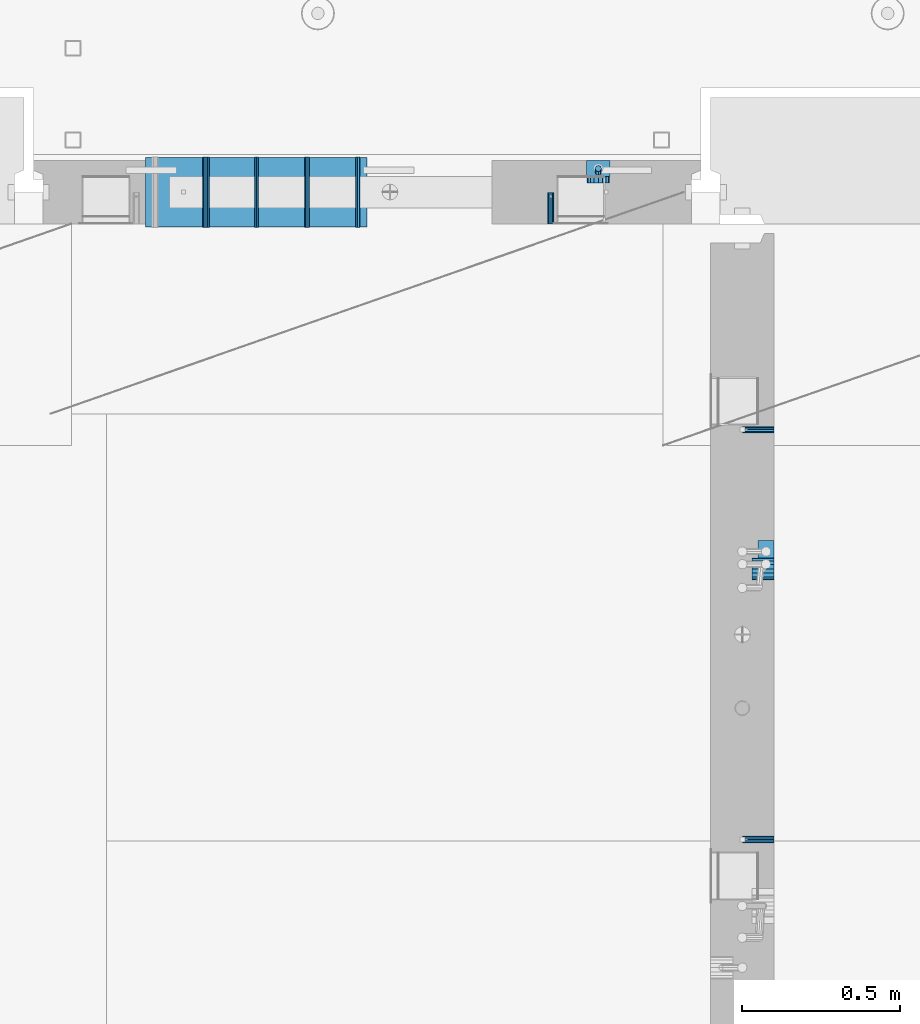
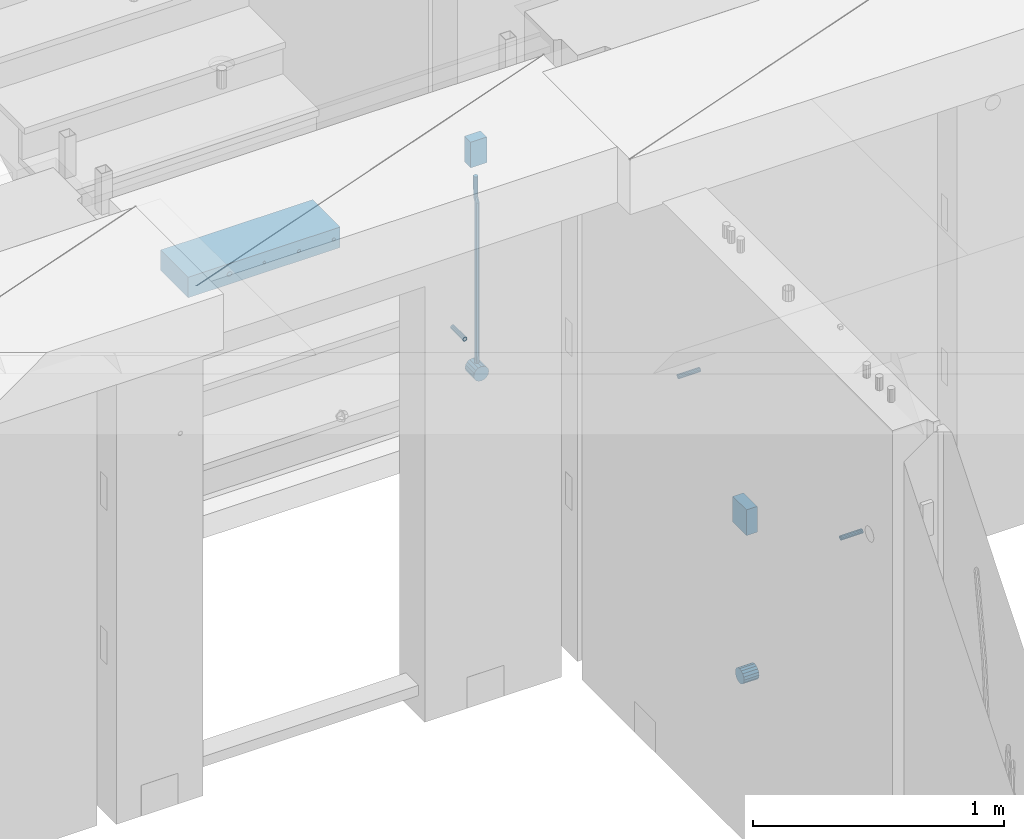
# One storey, part 149 of 349: 13 beams, 5 elements without a shape of their own.
"""IFC2X3 building model written with IfcOpenShell, lengths in millimetres."""

from ifc_helpers import new_model, si_unit, frame, origin_with_axes, place, context, subcontext, project, spatial, faceted_brep, material, type_object, element, aggregate, save


model = new_model("IFC2X3")

# Units and contexts
model_context = context("Model", 3, precision=1e-05, world=origin_with_axes())
body_context = subcontext(model_context, "Body", "Model", "MODEL_VIEW")
ifc_project = project(units=[si_unit("LENGTHUNIT", "METRE", prefix="MILLI"), si_unit("AREAUNIT", "SQUARE_METRE"), si_unit("VOLUMEUNIT", "CUBIC_METRE"), si_unit("MASSUNIT", "GRAM", prefix="KILO"), si_unit("TIMEUNIT", "SECOND"), si_unit("PLANEANGLEUNIT", "RADIAN"), si_unit("SOLIDANGLEUNIT", "STERADIAN"), si_unit("THERMODYNAMICTEMPERATUREUNIT", "DEGREE_CELSIUS"), si_unit("LUMINOUSINTENSITYUNIT", "LUMEN")], contexts=[model_context])

# Site, building, storey
site_placement = place(None, origin_with_axes())
site = spatial("IfcSite", under=ifc_project, at=site_placement, CompositionType="ELEMENT")
building_placement = place(site_placement, origin_with_axes())
building = spatial("IfcBuilding", under=site, at=building_placement, CompositionType="ELEMENT")
storey_placement = place(building_placement, origin_with_axes())
storey = spatial("IfcBuildingStorey", under=building, at=storey_placement, Name="4", CompositionType="ELEMENT", Elevation=0.0)

# Assemblies, beams
assembly_1_placement = place(storey_placement, origin_with_axes())
assembly_1 = element("IfcElementAssembly", 1, at=assembly_1_placement, inside=storey, AssemblyPlace="NOTDEFINED", PredefinedType="REINFORCEMENT_UNIT")
assembly_2_placement = place(assembly_1_placement, origin_with_axes())
assembly_2 = element("IfcElementAssembly", 2, at=assembly_2_placement, Name="Steel Assembly", AssemblyPlace="NOTDEFINED", PredefinedType="RIGID_FRAME")
ifc_material_1 = material(Name="STEEL/Steel_Undefined")
beam_type_1 = type_object("IfcBeamType", PredefinedType="NOTDEFINED")
beam_1_placement = place(assembly_2_placement, frame((21910.0, 13134.9999119588, 92555.0), z_axis=(0.0, -1.0, 0.0), x_axis=(-1.0, 3.00000001838171e-08, 0.0)))
beam_1 = element("IfcBeam", 3, at=beam_1_placement, type_object=beam_type_1, material=ifc_material_1, Name="M16", context=body_context, shape_type="Brep", body=[
    faceted_brep([(0.0, -8.49999999999272, -1.45519152283669e-11), (0.0, -7.36121593215648, 4.24999999998545), (100.000000000262, -7.36121593215648, 4.24999999998545), (100.000000000262, -8.49999999999272, -1.45519152283669e-11), (0.0, -4.24999999998545, 7.36121593216376), (100.000000000262, -4.24999999998545, 7.36121593216376), (0.0, 1.45519152283669e-11, 8.49999999998545), (100.000000000262, 1.45519152283669e-11, 8.49999999998545), (0.0, 4.25000000001455, 7.36121593216376), (100.000000000262, 4.25000000001455, 7.36121593216376), (0.0, 7.36121593217104, 4.24999999998545), (100.000000000262, 7.36121593217104, 4.24999999998545), (0.0, 8.50000000000728, 0.0), (100.000000000262, 8.50000000000728, 0.0), (0.0, 7.36121593217104, -4.25000000001455), (100.000000000262, 7.36121593217104, -4.25000000001455), (0.0, 4.25000000000728, -7.36121593219286), (100.000000000262, 4.25000000000728, -7.36121593219286), (0.0, 7.27595761418343e-12, -8.5), (100.000000000262, 7.27595761418343e-12, -8.5), (0.0, -4.24999999999272, -7.36121593217831), (100.000000000262, -4.24999999999272, -7.36121593217831), (0.0, -7.36121593215648, -4.25), (100.000000000262, -7.36121593215648, -4.25), (0.0, -10.4999999999927, -1.45519152283669e-11), (0.0, -9.09326673972828, -5.25000000001455), (100.000000000262, -9.09326673972828, -5.25000000001455), (100.000000000262, -10.4999999999927, -1.45519152283669e-11), (0.0, -5.24999999998545, -9.09326673974283), (100.000000000262, -5.24999999998545, -9.09326673974283), (0.0, 7.27595761418343e-12, -10.5), (100.000000000262, 7.27595761418343e-12, -10.5), (0.0, 5.25000000001455, -9.09326673975738), (100.000000000262, 5.25000000001455, -9.09326673975738), (0.0, 9.09326673975011, -5.25000000001455), (100.000000000262, 9.09326673975011, -5.25000000001455), (0.0, 10.5000000000073, -1.45519152283669e-11), (100.000000000262, 10.5000000000073, -1.45519152283669e-11), (0.0, 9.09326673975011, 5.25), (100.000000000262, 9.09326673975011, 5.25), (0.0, 5.25000000000728, 9.09326673972828), (100.000000000262, 5.25000000000728, 9.09326673972828), (0.0, 1.45519152283669e-11, 10.4999999999854), (100.000000000262, 1.45519152283669e-11, 10.4999999999854), (0.0, -5.24999999999272, 9.09326673972828), (100.000000000262, -5.24999999999272, 9.09326673972828), (0.0, -9.09326673972828, 5.24999999998545), (100.000000000262, -9.09326673972828, 5.24999999998545)], [[[0, 1, 2, 3]], [[1, 4, 5, 2]], [[4, 6, 7, 5]], [[6, 8, 9, 7]], [[8, 10, 11, 9]], [[10, 12, 13, 11]], [[12, 14, 15, 13]], [[14, 16, 17, 15]], [[16, 18, 19, 17]], [[18, 20, 21, 19]], [[20, 22, 23, 21]], [[22, 0, 3, 23]], [[24, 25, 26, 27]], [[25, 28, 29, 26]], [[28, 30, 31, 29]], [[30, 32, 33, 31]], [[32, 34, 35, 33]], [[34, 36, 37, 35]], [[36, 38, 39, 37]], [[38, 40, 41, 39]], [[40, 42, 43, 41]], [[42, 44, 45, 43]], [[44, 46, 47, 45]], [[46, 24, 27, 47]], [[29, 31, 33, 35, 37, 39, 41, 43, 45, 47, 27, 26], [5, 7, 9, 11, 13, 15, 17, 19, 21, 23, 3, 2]], [[46, 44, 42, 40, 38, 36, 34, 32, 30, 28, 25, 24], [22, 20, 18, 16, 14, 12, 10, 8, 6, 4, 1, 0]]]),
])
aggregate(assembly_2, [beam_1])
assembly_3_placement = place(assembly_1_placement, origin_with_axes())
assembly_3 = element("IfcElementAssembly", 4, at=assembly_3_placement, Name="Steel Assembly", AssemblyPlace="NOTDEFINED", PredefinedType="RIGID_FRAME")
beam_2_placement = place(assembly_3_placement, frame((21910.0, 14429.9999119589, 92555.0), z_axis=(0.0, 1.0, 0.0), x_axis=(-1.0, 3.00000001838171e-08, 0.0)))
beam_2 = element("IfcBeam", 5, at=beam_2_placement, type_object=beam_type_1, material=ifc_material_1, Name="M16", context=body_context, shape_type="Brep", body=[
    faceted_brep([(0.0, -8.49999999999272, -1.45519152283669e-11), (0.0, -7.36121593215648, 4.24999999998545), (100.000000000262, -7.36121593215648, 4.24999999998545), (100.000000000262, -8.49999999999272, -1.45519152283669e-11), (0.0, -4.24999999998545, 7.36121593216376), (100.000000000262, -4.24999999998545, 7.36121593216376), (0.0, 1.45519152283669e-11, 8.49999999998545), (100.000000000262, 1.45519152283669e-11, 8.49999999998545), (0.0, 4.25000000001455, 7.36121593216376), (100.000000000262, 4.25000000001455, 7.36121593216376), (0.0, 7.36121593217104, 4.24999999998545), (100.000000000262, 7.36121593217104, 4.24999999998545), (0.0, 8.50000000000728, 0.0), (100.000000000262, 8.50000000000728, 0.0), (0.0, 7.36121593217104, -4.25000000001455), (100.000000000262, 7.36121593217104, -4.25000000001455), (0.0, 4.25000000000728, -7.36121593219286), (100.000000000262, 4.25000000000728, -7.36121593219286), (0.0, 7.27595761418343e-12, -8.5), (100.000000000262, 7.27595761418343e-12, -8.5), (0.0, -4.24999999999272, -7.36121593217831), (100.000000000262, -4.24999999999272, -7.36121593217831), (0.0, -7.36121593215648, -4.25), (100.000000000262, -7.36121593215648, -4.25), (0.0, -10.4999999999927, -1.45519152283669e-11), (0.0, -9.09326673972828, -5.25000000001455), (100.000000000262, -9.09326673972828, -5.25000000001455), (100.000000000262, -10.4999999999927, -1.45519152283669e-11), (0.0, -5.24999999998545, -9.09326673974283), (100.000000000262, -5.24999999998545, -9.09326673974283), (0.0, 7.27595761418343e-12, -10.5), (100.000000000262, 7.27595761418343e-12, -10.5), (0.0, 5.25000000001455, -9.09326673975738), (100.000000000262, 5.25000000001455, -9.09326673975738), (0.0, 9.09326673975011, -5.25000000001455), (100.000000000262, 9.09326673975011, -5.25000000001455), (0.0, 10.5000000000073, -1.45519152283669e-11), (100.000000000262, 10.5000000000073, -1.45519152283669e-11), (0.0, 9.09326673975011, 5.25), (100.000000000262, 9.09326673975011, 5.25), (0.0, 5.25000000000728, 9.09326673972828), (100.000000000262, 5.25000000000728, 9.09326673972828), (0.0, 1.45519152283669e-11, 10.4999999999854), (100.000000000262, 1.45519152283669e-11, 10.4999999999854), (0.0, -5.24999999999272, 9.09326673972828), (100.000000000262, -5.24999999999272, 9.09326673972828), (0.0, -9.09326673972828, 5.24999999998545), (100.000000000262, -9.09326673972828, 5.24999999998545)], [[[0, 1, 2, 3]], [[1, 4, 5, 2]], [[4, 6, 7, 5]], [[6, 8, 9, 7]], [[8, 10, 11, 9]], [[10, 12, 13, 11]], [[12, 14, 15, 13]], [[14, 16, 17, 15]], [[16, 18, 19, 17]], [[18, 20, 21, 19]], [[20, 22, 23, 21]], [[22, 0, 3, 23]], [[24, 25, 26, 27]], [[25, 28, 29, 26]], [[28, 30, 31, 29]], [[30, 32, 33, 31]], [[32, 34, 35, 33]], [[34, 36, 37, 35]], [[36, 38, 39, 37]], [[38, 40, 41, 39]], [[40, 42, 43, 41]], [[42, 44, 45, 43]], [[44, 46, 47, 45]], [[46, 24, 27, 47]], [[29, 31, 33, 35, 37, 39, 41, 43, 45, 47, 27, 26], [5, 7, 9, 11, 13, 15, 17, 19, 21, 23, 3, 2]], [[46, 44, 42, 40, 38, 36, 34, 32, 30, 28, 25, 24], [22, 20, 18, 16, 14, 12, 10, 8, 6, 4, 1, 0]]]),
])
aggregate(assembly_3, [beam_2])

assembly_4_placement = place(storey_placement, origin_with_axes())
assembly_4 = element("IfcElementAssembly", 6, at=assembly_4_placement, inside=storey, AssemblyPlace="NOTDEFINED", PredefinedType="REINFORCEMENT_UNIT")
assembly_5_placement = place(assembly_4_placement, origin_with_axes())
assembly_5 = element("IfcElementAssembly", 7, at=assembly_5_placement, Name="Steel Assembly", AssemblyPlace="NOTDEFINED", PredefinedType="RIGID_FRAME")
beam_3_placement = place(assembly_5_placement, frame((21205.004085231, 15080.0, 92555.0), z_axis=(1.0, 0.0, 0.0), x_axis=(0.0, 1.0, 0.0)))
beam_3 = element("IfcBeam", 8, at=beam_3_placement, type_object=beam_type_1, material=ifc_material_1, Name="M16", context=body_context, shape_type="Brep", body=[
    faceted_brep([(0.0, -8.49999999999272, -1.45519152283669e-11), (0.0, -7.36121593215648, 4.24999999998545), (100.000000000262, -7.36121593215648, 4.24999999998545), (100.000000000262, -8.49999999999272, -1.45519152283669e-11), (0.0, -4.24999999998545, 7.36121593216376), (100.000000000262, -4.24999999998545, 7.36121593216376), (0.0, 1.45519152283669e-11, 8.49999999998545), (100.000000000262, 1.45519152283669e-11, 8.49999999998545), (0.0, 4.25000000001455, 7.36121593216376), (100.000000000262, 4.25000000001455, 7.36121593216376), (0.0, 7.36121593217104, 4.24999999998545), (100.000000000262, 7.36121593217104, 4.24999999998545), (0.0, 8.50000000000728, 0.0), (100.000000000262, 8.50000000000728, 0.0), (0.0, 7.36121593217104, -4.25000000001455), (100.000000000262, 7.36121593217104, -4.25000000001455), (0.0, 4.25000000000728, -7.36121593219286), (100.000000000262, 4.25000000000728, -7.36121593219286), (0.0, 7.27595761418343e-12, -8.5), (100.000000000262, 7.27595761418343e-12, -8.5), (0.0, -4.24999999999272, -7.36121593217831), (100.000000000262, -4.24999999999272, -7.36121593217831), (0.0, -7.36121593215648, -4.25), (100.000000000262, -7.36121593215648, -4.25), (0.0, -10.4999999999927, -1.45519152283669e-11), (0.0, -9.09326673972828, -5.25000000001455), (100.000000000262, -9.09326673972828, -5.25000000001455), (100.000000000262, -10.4999999999927, -1.45519152283669e-11), (0.0, -5.24999999998545, -9.09326673974283), (100.000000000262, -5.24999999998545, -9.09326673974283), (0.0, 7.27595761418343e-12, -10.5), (100.000000000262, 7.27595761418343e-12, -10.5), (0.0, 5.25000000001455, -9.09326673975738), (100.000000000262, 5.25000000001455, -9.09326673975738), (0.0, 9.09326673975011, -5.25000000001455), (100.000000000262, 9.09326673975011, -5.25000000001455), (0.0, 10.5000000000073, -1.45519152283669e-11), (100.000000000262, 10.5000000000073, -1.45519152283669e-11), (0.0, 9.09326673975011, 5.25), (100.000000000262, 9.09326673975011, 5.25), (0.0, 5.25000000000728, 9.09326673972828), (100.000000000262, 5.25000000000728, 9.09326673972828), (0.0, 1.45519152283669e-11, 10.4999999999854), (100.000000000262, 1.45519152283669e-11, 10.4999999999854), (0.0, -5.24999999999272, 9.09326673972828), (100.000000000262, -5.24999999999272, 9.09326673972828), (0.0, -9.09326673972828, 5.24999999998545), (100.000000000262, -9.09326673972828, 5.24999999998545)], [[[0, 1, 2, 3]], [[1, 4, 5, 2]], [[4, 6, 7, 5]], [[6, 8, 9, 7]], [[8, 10, 11, 9]], [[10, 12, 13, 11]], [[12, 14, 15, 13]], [[14, 16, 17, 15]], [[16, 18, 19, 17]], [[18, 20, 21, 19]], [[20, 22, 23, 21]], [[22, 0, 3, 23]], [[24, 25, 26, 27]], [[25, 28, 29, 26]], [[28, 30, 31, 29]], [[30, 32, 33, 31]], [[32, 34, 35, 33]], [[34, 36, 37, 35]], [[36, 38, 39, 37]], [[38, 40, 41, 39]], [[40, 42, 43, 41]], [[42, 44, 45, 43]], [[44, 46, 47, 45]], [[46, 24, 27, 47]], [[29, 31, 33, 35, 37, 39, 41, 43, 45, 47, 27, 26], [5, 7, 9, 11, 13, 15, 17, 19, 21, 23, 3, 2]], [[46, 44, 42, 40, 38, 36, 34, 32, 30, 28, 25, 24], [22, 20, 18, 16, 14, 12, 10, 8, 6, 4, 1, 0]]]),
])
aggregate(assembly_5, [beam_3])
ifc_material_2 = material()
beam_type_2 = type_object("IfcBeamType", Name="D20", PredefinedType="NOTDEFINED")
beam_4_placement = place(assembly_4_placement, frame((21354.9999999958, 15245.0000022759, 92290.0), z_axis=(0.00020576299992186, -0.999642804629538, -0.0267249099901004), x_axis=(-4.30000201928125e-08, -0.0267249099948059, 0.999642825806181)))
beam_4 = element("IfcBeam", 9, at=beam_4_placement, type_object=beam_type_2, material=ifc_material_2, Name="JM20", ObjectType="D20", context=body_context, shape_type="Brep", body=[
    faceted_brep([(0.0, -10.0, 0.0), (-4.19531716033816e-08, -7.07106781186667, -7.07106781187031), (60.3581158964225, -7.07106779467358, -7.07106780560207), (60.3581159005553, -9.99999998281055, 6.26459950581193e-09), (0.0, 0.0, -10.0), (60.3581158930319, 1.71930878423154e-08, -9.9999999937354), (4.196772351861e-08, 7.07106781186303, -7.07106781186667), (60.3581158923917, 7.07106782905612, -7.07106780560207), (0.0, 10.0, 0.0), (60.3581158948509, 10.0000000171895, 6.26459950581193e-09), (4.196772351861e-08, 7.07106781185939, 7.07106781185939), (60.3581158989837, 7.07106782905612, 7.07106781813127), (0.0, 0.0, 10.0), (60.3581159023597, 1.71930878423154e-08, 10.0000000062646), (-4.19531716033816e-08, -7.07106781187031, 7.07106781185939), (60.358115903, -7.07106779467722, 7.07106781813127), (60.8972477222414, -7.07106779452079, -7.07106780554386), (60.991799419251, -9.99999998403655, 6.21366780251265e-09), (60.8581158930319, 1.7334969015792e-08, -9.99999999368447), (60.8972861483926, 7.07106782920528, -7.07106780554386), (60.9917724058905, 10.0000000159635, 6.21366780251265e-09), (61.0863241029147, 7.07106782926348, 7.07106781820403), (61.1254559321096, 1.7415004549548e-08, 10.0000000063446), (61.086285676749, -7.07106779446985, 7.07106781820403), (61.4361869218264, -7.07107072394501, -7.08547838249069), (61.6251751877571, -10.0000034255863, -0.0169367769813107), (61.35793724822, -2.69946758635342e-06, -10.0133646071736), (61.4362637644808, 7.07106489957732, -7.08547940969947), (61.6252838596702, 9.99999657411536, -0.0169382296771801), (61.8142721256008, 7.07106387247404, 7.0516033758322), (61.8925217992073, -4.15200702263974e-06, 9.97948960051872), (61.814195282961, -7.07107175104829, 7.05160440304098), (775.690073058257, -7.07495307777208, -26.1837562433175), (775.879061324187, -10.0038857794134, -19.1152146378081), (775.611823384636, -0.00388505329101463, -29.1116424680004), (775.690149900896, 7.06718254575026, -26.1837572705263), (775.8791699961, 9.99611422029193, -19.1152160905003), (776.068158262031, 7.06718151865061, -12.0466744849909), (776.146407935637, -0.00388650583045091, -9.11878826030807), (776.068081419377, -7.07495410487172, -12.0466734577822), (776.844979390982, -7.07495935530824, -26.2146370302071), (778.703176670489, -10.0039011299996, -19.1907280380728), (776.111644739809, -0.00388777008629404, -29.1250070814895), (776.932750209904, 7.0671757915552, -26.2169828873994), (778.827303353013, 9.99609819560283, -19.1940455811236), (780.685500632535, 7.06715642091513, -12.1701365889894), (781.418835283708, -0.00391516431045602, -9.25976653770704), (780.597729813613, -7.07497872594467, -12.1677907318008), (777.861329320964, -7.08852484077215, -26.7638283058368), (781.188477298943, -10.0370730804789, -20.5336763496562), (776.551501535956, -0.00975865254440578, -29.362686553719), (778.026273295982, 7.05258025600779, -26.8078751783723), (781.421743305415, 9.96146953432981, -20.595968034173), (784.74889128338, 7.01292129462308, -14.3658160779887), (786.058719068402, -0.0658448936046625, -11.7669578301065), (784.583947308391, -7.12818380215685, -14.3217692054532), (795.432392943592, -7.32305037289916, -36.2584664814858), (798.759540921557, -10.2715986126059, -30.0283145252979), (794.12256515857, -0.244284184671415, -38.8573247293643), (795.597336918581, 6.81805472388078, -36.3025133540177), (798.992806928029, 9.72694400219916, -30.0906062098184), (802.319954905994, 6.77839576249244, -23.8604542536341), (803.629782691016, -0.300370425735309, -21.2615960057519), (802.15501093099, -7.3627093342875, -23.8164073811022), (799.505846831846, -7.3774198158244, -38.4595837060842), (801.367995818946, -10.3064143349802, -31.4378100447575), (798.762755292832, -0.306218002893729, -41.3646815597422), (799.574014147365, 6.7649769840682, -38.4513366830724), (801.464398961049, 9.69395502388943, -31.4261469929661), (803.32654794812, 6.76496050473361, -24.4043733316357), (804.069639487148, -0.306241308189783, -21.4992754779851), (803.258380632629, -7.37743629515535, -24.4126203546512), (804.134608044958, -7.36363999659807, -38.5831936197719), (804.332044311042, -10.2975903644801, -31.5169642204455), (804.035512197443, -0.290521008897485, -41.5054892177468), (804.092805771987, 6.77842942390271, -38.5720098863276), (804.272926969657, 9.70231601001069, -31.5011480329304), (804.470363235741, 6.76836564212863, -24.434918633604), (804.569459083272, -0.304753345568315, -21.5126230356327), (804.512165508728, -7.37370377836123, -24.4461023670447), (901.742523775247, -7.07306129268909, -41.1897886639781), (901.939960041316, -10.0070116605639, -34.1235592646481), (901.643427927731, 5.76950078539085e-05, -44.1120842619457), (901.700721502275, 7.06900812780805, -41.1786049305338), (901.880842699946, 9.99289471391967, -34.1077430771329), (902.07827896603, 7.05894434603761, -27.0415136778065), (902.177374813546, -0.0141746416556998, -24.1192180798353), (902.120081238987, -7.08312507445589, -27.0526974112508)], [[[0, 1, 2, 3]], [[1, 4, 5, 2]], [[4, 6, 7, 5]], [[6, 8, 9, 7]], [[8, 10, 11, 9]], [[10, 12, 13, 11]], [[12, 14, 15, 13]], [[14, 0, 3, 15]], [[14, 12, 10, 8, 6, 4, 1, 0]], [[3, 2, 16, 17]], [[2, 5, 18, 16]], [[5, 7, 19, 18]], [[7, 9, 20, 19]], [[9, 11, 21, 20]], [[11, 13, 22, 21]], [[13, 15, 23, 22]], [[15, 3, 17, 23]], [[17, 16, 24, 25]], [[16, 18, 26, 24]], [[18, 19, 27, 26]], [[19, 20, 28, 27]], [[20, 21, 29, 28]], [[21, 22, 30, 29]], [[22, 23, 31, 30]], [[23, 17, 25, 31]], [[25, 24, 32, 33]], [[24, 26, 34, 32]], [[26, 27, 35, 34]], [[27, 28, 36, 35]], [[28, 29, 37, 36]], [[29, 30, 38, 37]], [[30, 31, 39, 38]], [[31, 25, 33, 39]], [[33, 32, 40, 41]], [[32, 34, 42, 40]], [[34, 35, 43, 42]], [[35, 36, 44, 43]], [[36, 37, 45, 44]], [[37, 38, 46, 45]], [[38, 39, 47, 46]], [[39, 33, 41, 47]], [[41, 40, 48, 49]], [[40, 42, 50, 48]], [[42, 43, 51, 50]], [[43, 44, 52, 51]], [[44, 45, 53, 52]], [[45, 46, 54, 53]], [[46, 47, 55, 54]], [[47, 41, 49, 55]], [[49, 48, 56, 57]], [[48, 50, 58, 56]], [[50, 51, 59, 58]], [[51, 52, 60, 59]], [[52, 53, 61, 60]], [[53, 54, 62, 61]], [[54, 55, 63, 62]], [[55, 49, 57, 63]], [[57, 56, 64, 65]], [[56, 58, 66, 64]], [[58, 59, 67, 66]], [[59, 60, 68, 67]], [[60, 61, 69, 68]], [[61, 62, 70, 69]], [[62, 63, 71, 70]], [[63, 57, 65, 71]], [[65, 64, 72, 73]], [[64, 66, 74, 72]], [[66, 67, 75, 74]], [[67, 68, 76, 75]], [[68, 69, 77, 76]], [[69, 70, 78, 77]], [[70, 71, 79, 78]], [[71, 65, 73, 79]], [[73, 72, 80, 81]], [[72, 74, 82, 80]], [[74, 75, 83, 82]], [[75, 76, 84, 83]], [[76, 77, 85, 84]], [[77, 78, 86, 85]], [[78, 79, 87, 86]], [[79, 73, 81, 87]], [[82, 83, 84, 85, 86, 87, 81, 80]]]),
])

# Beam
beam_type_3 = type_object("IfcBeamType", Name="D70", PredefinedType="NOTDEFINED")
beam_5_placement = place(assembly_1_placement, frame((21910.0000022791, 13990.0, 91355.0), z_axis=(0.0, 0.0, 1.0), x_axis=(-1.0, 3.00000001838171e-08, 0.0)))
beam_5 = element("IfcBeam", 10, at=beam_5_placement, type_object=beam_type_3, material=ifc_material_2, ObjectType="D70", context=body_context, shape_type="Brep", body=[
    faceted_brep([(0.0, -35.0, 0.0), (0.0, -32.3357836378964, -13.3939201327739), (70.0, -32.3357836378964, -13.3939201327739), (70.0, -35.0, 0.0), (0.0, -24.7487373415279, -24.7487373415352), (70.0, -24.7487373415279, -24.7487373415352), (0.0, -13.3939201327776, -32.3357836379), (70.0, -13.3939201327776, -32.3357836379), (0.0, 0.0, -35.0), (70.0, 0.0, -35.0), (0.0, 13.3939201327776, -32.3357836379), (70.0, 13.3939201327776, -32.3357836379), (0.0, 24.7487373415279, -24.7487373415352), (70.0, 24.7487373415279, -24.7487373415352), (0.0, 32.3357836378964, -13.3939201327739), (70.0, 32.3357836378964, -13.3939201327739), (0.0, 35.0, 0.0), (70.0, 35.0, 0.0), (0.0, 32.3357836378964, 13.3939201327739), (70.0, 32.3357836378964, 13.3939201327739), (0.0, 24.7487373415279, 24.7487373415352), (70.0, 24.7487373415279, 24.7487373415352), (0.0, 13.3939201327776, 32.3357836379), (70.0, 13.3939201327776, 32.3357836379), (0.0, 0.0, 35.0), (70.0, 0.0, 35.0), (0.0, -13.3939201327776, 32.3357836379), (70.0, -13.3939201327776, 32.3357836379), (0.0, -24.7487373415279, 24.7487373415352), (70.0, -24.7487373415279, 24.7487373415352), (0.0, -32.3357836378964, 13.3939201327739), (70.0, -32.3357836378964, 13.3939201327739)], [[[0, 1, 2, 3]], [[1, 4, 5, 2]], [[4, 6, 7, 5]], [[6, 8, 9, 7]], [[8, 10, 11, 9]], [[10, 12, 13, 11]], [[12, 14, 15, 13]], [[14, 16, 17, 15]], [[16, 18, 19, 17]], [[18, 20, 21, 19]], [[20, 22, 23, 21]], [[22, 24, 25, 23]], [[24, 26, 27, 25]], [[26, 28, 29, 27]], [[28, 30, 31, 29]], [[30, 0, 3, 31]], [[5, 7, 9, 11, 13, 15, 17, 19, 21, 23, 25, 27, 29, 31, 3, 2]], [[30, 28, 26, 24, 22, 20, 18, 16, 14, 12, 10, 8, 6, 4, 1, 0]]]),
])

beam_6_placement = place(assembly_4_placement, frame((21354.9999999996, 15280.0000022759, 92255.0), z_axis=(0.0, 0.0, 1.0), x_axis=(0.0, -1.0, 0.0)))
beam_6 = element("IfcBeam", 11, at=beam_6_placement, type_object=beam_type_3, material=ifc_material_2, ObjectType="D70", context=body_context, shape_type="Brep", body=[
    faceted_brep([(0.0, -35.0, 0.0), (0.0, -32.3357836378964, -13.3939201327739), (70.0, -32.3357836378964, -13.3939201327739), (70.0, -35.0, 0.0), (0.0, -24.7487373415279, -24.7487373415352), (70.0, -24.7487373415279, -24.7487373415352), (0.0, -13.3939201327776, -32.3357836379), (70.0, -13.3939201327776, -32.3357836379), (0.0, 0.0, -35.0), (70.0, 0.0, -35.0), (0.0, 13.3939201327776, -32.3357836379), (70.0, 13.3939201327776, -32.3357836379), (0.0, 24.7487373415279, -24.7487373415352), (70.0, 24.7487373415279, -24.7487373415352), (0.0, 32.3357836378964, -13.3939201327739), (70.0, 32.3357836378964, -13.3939201327739), (0.0, 35.0, 0.0), (70.0, 35.0, 0.0), (0.0, 32.3357836378964, 13.3939201327739), (70.0, 32.3357836378964, 13.3939201327739), (0.0, 24.7487373415279, 24.7487373415352), (70.0, 24.7487373415279, 24.7487373415352), (0.0, 13.3939201327776, 32.3357836379), (70.0, 13.3939201327776, 32.3357836379), (0.0, 0.0, 35.0), (70.0, 0.0, 35.0), (0.0, -13.3939201327776, 32.3357836379), (70.0, -13.3939201327776, 32.3357836379), (0.0, -24.7487373415279, 24.7487373415352), (70.0, -24.7487373415279, 24.7487373415352), (0.0, -32.3357836378964, 13.3939201327739), (70.0, -32.3357836378964, 13.3939201327739)], [[[0, 1, 2, 3]], [[1, 4, 5, 2]], [[4, 6, 7, 5]], [[6, 8, 9, 7]], [[8, 10, 11, 9]], [[10, 12, 13, 11]], [[12, 14, 15, 13]], [[14, 16, 17, 15]], [[16, 18, 19, 17]], [[18, 20, 21, 19]], [[20, 22, 23, 21]], [[22, 24, 25, 23]], [[24, 26, 27, 25]], [[26, 28, 29, 27]], [[28, 30, 31, 29]], [[30, 0, 3, 31]], [[5, 7, 9, 11, 13, 15, 17, 19, 21, 23, 25, 27, 29, 31, 3, 2]], [[30, 28, 26, 24, 22, 20, 18, 16, 14, 12, 10, 8, 6, 4, 1, 0]]]),
])

ifc_material_3 = material()
beam_type_4 = type_object("IfcBeamType", Name="D12", PredefinedType="NOTDEFINED")
beam_7_placement = place(assembly_4_placement, frame((20274.9991455079, 15068.9997314798, 93260.0), z_axis=(-1.0, 3.00000001838171e-08, 0.0), x_axis=(0.0, 1.0, 0.0)))
beam_7 = element("IfcBeam", 12, at=beam_7_placement, type_object=beam_type_4, material=ifc_material_3, Name="12", ObjectType="D12", context=body_context, shape_type="Brep", body=[
    faceted_brep([(0.0, -6.0, -1.45519152283669e-11), (0.0, -4.24264068712, -4.24264068713819), (222.000077784061, -4.24264068712364, -4.24264068712), (222.000077784061, -6.0, 0.0), (3.63797880709171e-12, 0.0, -6.0000000000291), (222.000077784061, 0.0, -6.0), (0.0, 4.24264068712, -4.24264068713819), (222.000077784061, 4.24264068712364, -4.24264068712), (0.0, 6.0, -1.45519152283669e-11), (222.000077784061, 6.0, 0.0), (0.0, 4.24264068712, 4.24264068709454), (222.000077784061, 4.24264068712364, 4.24264068712), (0.0, 0.0, 5.99999999998545), (222.000077784061, 0.0, 6.0), (0.0, -4.24264068712, 4.24264068709454), (222.000077784061, -4.24264068712364, 4.24264068712)], [[[0, 1, 2, 3]], [[1, 4, 5, 2]], [[4, 6, 7, 5]], [[6, 8, 9, 7]], [[8, 10, 11, 9]], [[10, 12, 13, 11]], [[12, 14, 15, 13]], [[14, 0, 3, 15]], [[5, 7, 9, 11, 13, 15, 3, 2]], [[14, 12, 10, 8, 6, 4, 1, 0]]]),
])

beam_type_5 = type_object("IfcBeamType", Name="D15", PredefinedType="NOTDEFINED")
beam_8_placement = place(assembly_4_placement, frame((20594.99899292, 15068.9997314793, 93260.0), z_axis=(-1.0, 3.00000001838171e-08, 0.0), x_axis=(0.0, 1.0, 0.0)))
beam_8 = element("IfcBeam", 13, at=beam_8_placement, type_object=beam_type_5, material=ifc_material_3, Name="15", ObjectType="D15", context=body_context, shape_type="Brep", body=[
    faceted_brep([(0.0, -7.5, 0.0), (0.0, -5.30330085889727, -5.30330085890091), (222.000077784061, -5.30330085889727, -5.30330085890091), (222.000077784061, -7.5, 0.0), (0.0, 1.45519152283669e-11, -7.5), (222.000077784061, 0.0, -7.5), (0.0, 5.30330085889727, -5.30330085890091), (222.000077784061, 5.30330085889727, -5.30330085890091), (0.0, 7.5, 0.0), (222.000077784061, 7.5, 0.0), (0.0, 5.30330085889727, 5.30330085890091), (222.000077784061, 5.30330085889727, 5.30330085890091), (0.0, 1.45519152283669e-11, 7.5), (222.000077784061, 0.0, 7.5), (0.0, -5.30330085889727, 5.30330085890091), (222.000077784061, -5.30330085889727, 5.30330085890091)], [[[0, 1, 2, 3]], [[1, 4, 5, 2]], [[4, 6, 7, 5]], [[6, 8, 9, 7]], [[8, 10, 11, 9]], [[10, 12, 13, 11]], [[12, 14, 15, 13]], [[14, 0, 3, 15]], [[5, 7, 9, 11, 13, 15, 3, 2]], [[14, 12, 10, 8, 6, 4, 1, 0]]]),
])

beam_9_placement = place(assembly_4_placement, frame((20434.9991455079, 15068.9997314796, 93260.0), z_axis=(-1.0, 3.00000001838171e-08, 0.0), x_axis=(0.0, 1.0, 0.0)))
beam_9 = element("IfcBeam", 14, at=beam_9_placement, type_object=beam_type_5, material=ifc_material_3, Name="15", ObjectType="D15", context=body_context, shape_type="Brep", body=[
    faceted_brep([(0.0, -7.5, 0.0), (0.0, -5.30330085889727, -5.30330085890091), (222.000077784061, -5.30330085889727, -5.30330085890091), (222.000077784061, -7.5, 0.0), (0.0, 1.45519152283669e-11, -7.5), (222.000077784061, 0.0, -7.5), (0.0, 5.30330085889727, -5.30330085890091), (222.000077784061, 5.30330085889727, -5.30330085890091), (0.0, 7.5, 0.0), (222.000077784061, 7.5, 0.0), (0.0, 5.30330085889727, 5.30330085890091), (222.000077784061, 5.30330085889727, 5.30330085890091), (0.0, 1.45519152283669e-11, 7.5), (222.000077784061, 0.0, 7.5), (0.0, -5.30330085889727, 5.30330085890091), (222.000077784061, -5.30330085889727, 5.30330085890091)], [[[0, 1, 2, 3]], [[1, 4, 5, 2]], [[4, 6, 7, 5]], [[6, 8, 9, 7]], [[8, 10, 11, 9]], [[10, 12, 13, 11]], [[12, 14, 15, 13]], [[14, 0, 3, 15]], [[5, 7, 9, 11, 13, 15, 3, 2]], [[14, 12, 10, 8, 6, 4, 1, 0]]]),
])

beam_type_6 = type_object("IfcBeamType", Name="D22", PredefinedType="NOTDEFINED")
beam_10_placement = place(assembly_4_placement, frame((20114.9991455079, 15068.9997314801, 93260.0), z_axis=(-1.0, 3.00000001838171e-08, 0.0), x_axis=(0.0, 1.0, 0.0)))
beam_10 = element("IfcBeam", 15, at=beam_10_placement, type_object=beam_type_6, material=ifc_material_3, Name="22", ObjectType="D22", context=body_context, shape_type="Brep", body=[
    faceted_brep([(0.0, -11.0, 0.0), (0.0, -9.52627944163396, -5.5), (222.000077784061, -9.52627944163396, -5.5), (222.000077784061, -11.0, 0.0), (0.0, -5.5, -9.52627944163032), (222.000077784061, -5.5, -9.52627944163032), (0.0, 0.0, -11.0), (222.000077784061, 0.0, -11.0), (0.0, 5.5, -9.52627944163032), (222.000077784061, 5.5, -9.52627944163032), (0.0, 9.52627944163396, -5.5), (222.000077784061, 9.52627944163396, -5.5), (0.0, 11.0, 0.0), (222.000077784061, 11.0, 0.0), (0.0, 9.52627944163396, 5.5), (222.000077784061, 9.52627944163396, 5.5), (0.0, 5.5, 9.52627944163032), (222.000077784061, 5.5, 9.52627944163032), (0.0, 0.0, 11.0), (222.000077784061, 0.0, 11.0), (0.0, -5.5, 9.52627944163032), (222.000077784061, -5.5, 9.52627944163032), (0.0, -9.52627944163396, 5.5), (222.000077784061, -9.52627944163396, 5.5)], [[[0, 1, 2, 3]], [[1, 4, 5, 2]], [[4, 6, 7, 5]], [[6, 8, 9, 7]], [[8, 10, 11, 9]], [[10, 12, 13, 11]], [[12, 14, 15, 13]], [[14, 16, 17, 15]], [[16, 18, 19, 17]], [[18, 20, 21, 19]], [[20, 22, 23, 21]], [[22, 0, 3, 23]], [[5, 7, 9, 11, 13, 15, 17, 19, 21, 23, 3, 2]], [[22, 20, 18, 16, 14, 12, 10, 8, 6, 4, 1, 0]]]),
])

beam_type_7 = type_object("IfcBeamType", PredefinedType="NOTDEFINED")
beam_11_placement = place(assembly_4_placement, frame((20274.9991455078, 15069.9997314811, 93260.0), z_axis=(-1.0, 3.00000001838171e-08, 0.0), x_axis=(0.0, 1.0, 0.0)))
beam_11 = element("IfcBeam", 16, at=beam_11_placement, type_object=beam_type_7, material=ifc_material_3, context=body_context, shape_type="Brep", body=[
    faceted_brep([(0.0, 50.0, -350.0), (0.0, 50.0, 350.0), (220.000077784061, 50.0, 350.0), (220.000077784061, 50.0, -350.0), (0.0, -50.0, 350.0), (220.000077784061, -50.0, 350.0), (0.0, -50.0, -350.0), (220.000077784061, -50.0, -350.0)], [[[0, 1, 2, 3]], [[1, 4, 5, 2]], [[4, 6, 7, 5]], [[6, 0, 3, 7]], [[5, 7, 3, 2]], [[6, 4, 1, 0]]]),
])

beam_type_8 = type_object("IfcBeamType", Name="125X50", PredefinedType="NOTDEFINED")
beam_12_placement = place(assembly_1_placement, frame((21885.0, 13970.0, 92105.0), z_axis=(0.0, 0.0, 1.0), x_axis=(0.0, 1.0, 0.0)))
beam_12 = element("IfcBeam", 17, at=beam_12_placement, type_object=beam_type_8, material=ifc_material_2, Name="WM2", ObjectType="125X50", context=body_context, shape_type="Brep", body=[
    faceted_brep([(0.0, 25.0, -62.5), (0.0, 25.0, 62.5), (110.0, 25.0, 62.5), (110.0, 25.0, -62.5), (0.0, -25.0, 62.5), (110.0, -25.0, 62.5), (0.0, -25.0, -62.5), (110.0, -25.0, -62.5)], [[[0, 1, 2, 3]], [[1, 4, 5, 2]], [[4, 6, 7, 5]], [[6, 0, 3, 7]], [[5, 7, 3, 2]], [[0, 6, 4, 1]]]),
])

aggregate(assembly_1, [assembly_2, assembly_3, beam_12, beam_5])

beam_13_placement = place(assembly_4_placement, frame((21392.4999999996, 15254.9999999967, 93320.0), z_axis=(0.0, 0.0, 1.0), x_axis=(-1.0, 3.00000001838171e-08, 0.0)))
beam_13 = element("IfcBeam", 18, at=beam_13_placement, type_object=beam_type_8, material=ifc_material_2, Name="WM1", ObjectType="125X50", context=body_context, shape_type="Brep", body=[
    faceted_brep([(0.0, 25.0, -62.5), (0.0, 25.0, 62.5), (75.0, 25.0, 62.5), (75.0, 25.0, -62.5), (0.0, -25.0, 62.5), (75.0, -25.0, 62.5), (0.0, -25.0, -62.5), (75.0, -25.0, -62.5)], [[[0, 1, 2, 3]], [[1, 4, 5, 2]], [[4, 6, 7, 5]], [[6, 0, 3, 7]], [[5, 7, 3, 2]], [[0, 6, 4, 1]]]),
])

aggregate(assembly_4, [assembly_5, beam_13, beam_4, beam_6, beam_10, beam_7, beam_11, beam_8, beam_9])

save(model, "model.ifc")
